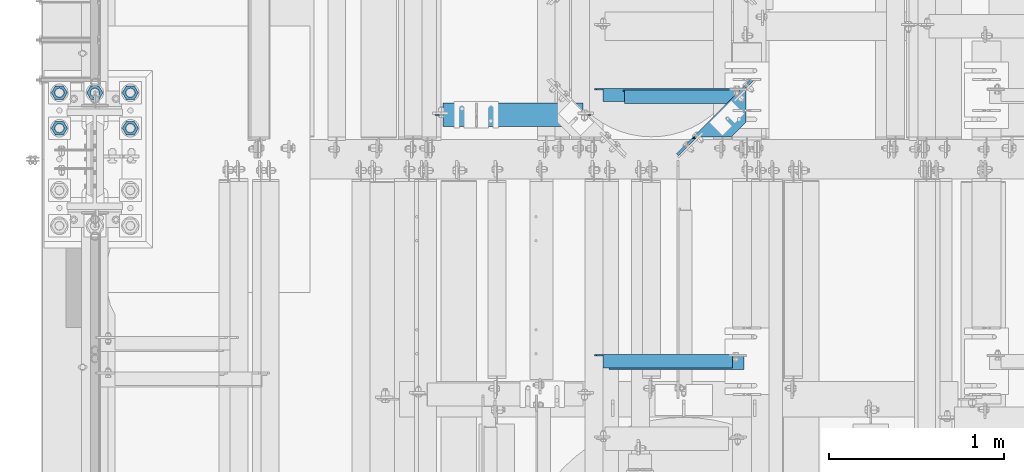
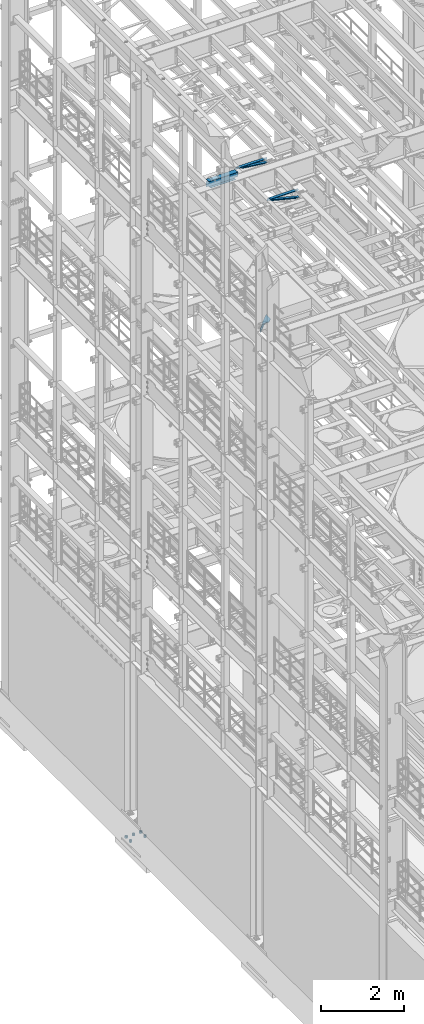
# One storey, part 1291 of 1876: 11 beams, 7 elements without a shape of their own.
"""IFC2X3 building model written with IfcOpenShell, lengths in millimetres."""

from ifc_helpers import new_model, si_unit, frame, origin_with_axes, place, context, subcontext, project, spatial, faceted_brep, material, type_object, element, aggregate, save


model = new_model("IFC2X3")

# Units and contexts
model_context = context("Model", 3, precision=1e-05, world=origin_with_axes())
body_context = subcontext(model_context, "Body", "Model", "MODEL_VIEW")
ifc_project = project(units=[si_unit("LENGTHUNIT", "METRE", prefix="MILLI"), si_unit("AREAUNIT", "SQUARE_METRE"), si_unit("VOLUMEUNIT", "CUBIC_METRE"), si_unit("MASSUNIT", "GRAM", prefix="KILO"), si_unit("TIMEUNIT", "SECOND"), si_unit("PLANEANGLEUNIT", "RADIAN"), si_unit("SOLIDANGLEUNIT", "STERADIAN"), si_unit("THERMODYNAMICTEMPERATUREUNIT", "DEGREE_CELSIUS"), si_unit("LUMINOUSINTENSITYUNIT", "LUMEN")], contexts=[model_context])

# Site, building, storey
site_placement = place(None, origin_with_axes())
site = spatial("IfcSite", under=ifc_project, at=site_placement, CompositionType="ELEMENT")
building_placement = place(site_placement, origin_with_axes())
building = spatial("IfcBuilding", under=site, at=building_placement, Name="Undefined", CompositionType="ELEMENT")
storey_placement = place(building_placement, origin_with_axes())
storey = spatial("IfcBuildingStorey", under=building, at=storey_placement, Name="Undefined", CompositionType="ELEMENT", Elevation=0.0)

# Assembly, beam
assembly_1_placement = place(storey_placement, origin_with_axes())
assembly_1 = element("IfcElementAssembly", 1, at=assembly_1_placement, inside=storey, AssemblyPlace="NOTDEFINED", PredefinedType="RIGID_FRAME")
ifc_material_1 = material(Name="STEEL/A36")
beam_type_1 = type_object("IfcBeamType", Name="L3X3X3/8", PredefinedType="NOTDEFINED")
beam_1_placement = place(assembly_1_placement, frame((2848.13301311816, 6454.18006051547, 17946.2692677152), z_axis=(0.0, -1.0, 0.0), x_axis=(0.969310558580603, 1.00000000454371e-07, -0.245839461893631)))
beam_1 = element("IfcBeam", 2, at=beam_1_placement, type_object=beam_type_1, material=ifc_material_1, ObjectType="L3X3X3/8", context=body_context, shape_type="Brep", body=[
    faceted_brep([(90.4045258935405, 38.0999999998276, -38.0999999999794), (90.4045258813046, 38.0999999997985, 38.1000000000213), (887.66431198654, 38.0999999985725, 38.1000000001395), (887.664311998776, 38.0999999986052, -38.0999999998612), (90.4045258813187, 28.5749999998079, 38.1000000000195), (887.664311986553, 28.5749999985892, 38.1000000001368), (90.4045258920253, 28.574999999837, -28.5749999999816), (887.664311997261, 28.5749999986147, -28.5749999998634), (90.4045258921208, -38.1000000000786, -28.5749999999953), (887.664311997356, -38.1000000012973, -28.5749999998779), (90.404525893651, -38.1000000000749, -38.0999999999967), (887.664311998886, -38.1000000012937, -38.0999999998776)], [[[0, 1, 2, 3]], [[1, 4, 5, 2]], [[4, 6, 7, 5]], [[6, 8, 9, 7]], [[8, 10, 11, 9]], [[10, 0, 3, 11]], [[5, 7, 9, 11, 3, 2]], [[10, 8, 6, 4, 1, 0]]]),
])
aggregate(assembly_1, [beam_1])

assembly_2_placement = place(storey_placement, origin_with_axes())
assembly_2 = element("IfcElementAssembly", 3, at=assembly_2_placement, inside=storey, Name="ANGLE", AssemblyPlace="NOTDEFINED", PredefinedType="RIGID_FRAME")
beam_2_placement = place(assembly_2_placement, frame((2857.49949562797, 6463.70506140095, 17945.1), z_axis=(0.0, -1.0, 0.0), x_axis=(1.0, 0.0, 0.0)))
beam_2 = element("IfcBeam", 4, at=beam_2_placement, type_object=beam_type_1, material=ifc_material_1, Name="ANGLE", ObjectType="L3X3X3/8", context=body_context, shape_type="Brep", body=[
    faceted_brep([(792.16350731529, 28.5750000000007, -28.5750000002181), (792.163500447734, 28.5750000000007, 38.0999999997821), (52.3875000813123, 28.5750001907327, 38.0999999999858), (52.3875051486311, 28.5750000000007, -28.5750000000144), (792.16312546001, 38.0999999999985, 38.099999999783), (52.3875000813496, 38.0999999999985, 38.0999999999858), (15.8755031573583, 28.5750000000007, -28.5750000000053), (15.875503881261, 28.5750001907327, -38.1000000000049), (3.17550407199587, 15.8750003814675, -38.1000000000013), (3.17550334809312, 15.8750003814675, -28.5750000000016), (52.3875058725339, 28.5750001907327, -38.1000000000149), (52.3875058725371, 38.0999999999985, -38.1000000000149), (792.16313330825, 38.0999999999985, -38.1000000002177), (792.163508296368, 28.5750017223145, -38.1000000002186), (860.425509047713, 28.5750000000007, -28.5750000002372), (860.425510028792, 28.5750017223145, -38.1000000002377), (873.125508856978, 15.8750030560368, -28.5750000002408), (873.125509838057, 15.8750019130493, -38.1000000002414), (873.125508856978, 3.17500420044598, -28.5750000002408), (873.125509838057, 3.17500305745853, -38.1000000002414), (873.125507331097, -38.0999999999985, -28.5750000002408), (873.125508312176, -38.0999999999985, -38.1000000002405), (3.17550731526535, -38.0999999999985, -28.5750000000007), (3.17550829634501, -38.0999999999985, -38.1000000000013), (3.17550407199587, 3.17500152587672, -38.1000000000013), (3.17550334809312, 3.17500152587672, -28.5750000000016)], [[[0, 1, 2, 3]], [[1, 4, 5, 2]], [[6, 7, 8, 9]], [[3, 10, 7, 6]], [[2, 5, 11, 10, 3]], [[4, 12, 11, 5]], [[1, 0, 13, 12, 4]], [[14, 15, 13, 0]], [[16, 17, 15, 14]], [[18, 19, 17, 16]], [[19, 18, 20, 21]], [[21, 20, 22, 23]], [[8, 7, 10, 11, 12, 13, 15, 17, 19, 21, 23, 24]], [[9, 8, 24, 25]], [[20, 18, 16, 14, 0, 3, 6, 9, 25, 22]], [[24, 23, 22, 25]]]),
])
aggregate(assembly_2, [beam_2])

assembly_3_placement = place(storey_placement, origin_with_axes())
assembly_3 = element("IfcElementAssembly", 5, at=assembly_3_placement, inside=storey, AssemblyPlace="NOTDEFINED", PredefinedType="RIGID_FRAME")
beam_3_placement = place(assembly_3_placement, frame((2852.70682935148, 7978.18213610312, 17945.4027002496), z_axis=(0.0, -1.0, 0.0), x_axis=(0.992055111518437, 1.02000000268371e-07, -0.125804036938932)))
beam_3 = element("IfcBeam", 6, at=beam_3_placement, type_object=beam_type_1, material=ifc_material_1, ObjectType="L3X3X3/8", context=body_context, shape_type="Brep", body=[
    faceted_brep([(176.663647192054, 38.0999999999221, -38.0999999999594), (176.663647205919, 38.0999999998421, 38.1000000000404), (867.316103043101, 38.0999999995292, 38.1000000001568), (867.316103029236, 38.0999999996056, -38.099999999843), (176.663647205922, 28.5749999998552, 38.1000000000377), (867.316103043104, 28.5749999995423, 38.100000000155), (176.663647193791, 28.5749999999207, -28.5749999999625), (867.316103030973, 28.5749999996078, -28.5749999998452), (176.663647193814, -38.1000000000131, -28.5749999999789), (867.316103030995, -38.1000000003223, -28.5749999998607), (176.663647192081, -38.1000000000022, -38.0999999999785), (867.316103029262, -38.1000000003114, -38.0999999998612)], [[[0, 1, 2, 3]], [[1, 4, 5, 2]], [[4, 6, 7, 5]], [[6, 8, 9, 7]], [[8, 10, 11, 9]], [[10, 0, 3, 11]], [[5, 7, 9, 11, 3, 2]], [[10, 8, 6, 4, 1, 0]]]),
])
aggregate(assembly_3, [beam_3])

assembly_4_placement = place(storey_placement, origin_with_axes())
assembly_4 = element("IfcElementAssembly", 7, at=assembly_4_placement, inside=storey, Name="ANGLE", AssemblyPlace="NOTDEFINED", PredefinedType="RIGID_FRAME")
beam_4_placement = place(assembly_4_placement, frame((2857.4999621662, 7987.7071365963, 17945.1), z_axis=(0.0, -1.0, 0.0), x_axis=(1.0, 0.0, 0.0)))
beam_4 = element("IfcBeam", 8, at=beam_4_placement, type_object=beam_type_1, material=ifc_material_1, Name="ANGLE", ObjectType="L3X3X3/8", context=body_context, shape_type="Brep", body=[
    faceted_brep([(792.163346802882, 28.5750000000007, -28.5750000002181), (792.163339935326, 28.5750000000007, 38.0999999997821), (52.3870335430847, 28.5750001907327, 38.0999999999858), (52.3869956588824, 28.5749999999955, -28.5750000000007), (792.162964935728, 38.0999999999985, 38.099999999783), (52.387033543122, 38.0999999999985, 38.0999999999858), (15.8750625152097, 28.5750000000007, -28.5749999999953), (15.8750613722059, 28.5750001907327, -38.0999999999958), (3.17506156294075, 15.8750003814675, -38.0999999999995), (3.17506270594458, 15.8750003814675, -28.5749999999989), (52.3870393343063, 28.5750001907327, -38.1000000000149), (52.3869953826566, 38.0999999999954, -38.0999999999985), (792.162972783968, 38.0999999999985, -38.1000000002177), (792.163347783961, 28.5750017223145, -38.1000000002186), (860.425348519473, 28.5750000000007, -28.5750000002372), (860.425349500552, 28.5750017223145, -38.1000000002368), (873.125348328738, 15.8750030560368, -28.5750000002408), (873.125349309817, 15.8750019130493, -38.1000000002405), (873.125348328738, 3.17500420044598, -28.5750000002408), (873.125349309817, 3.17500305745853, -38.1000000002405), (873.125346802857, -38.0999999999985, -28.5750000002408), (873.125347783936, -38.0999999999985, -38.1000000002405), (3.17506206535836, -38.0999999999985, -28.5749999999989), (3.17506108428279, -38.0999999999985, -38.0999999999995), (3.17506156294075, 3.17500152587672, -38.0999999999995), (3.17506270594458, 3.17500152587672, -28.5749999999989)], [[[0, 1, 2, 3]], [[1, 4, 5, 2]], [[6, 7, 8, 9]], [[3, 10, 7, 6]], [[2, 5, 11, 10, 3]], [[4, 12, 11, 5]], [[1, 0, 13, 12, 4]], [[14, 15, 13, 0]], [[16, 17, 15, 14]], [[18, 19, 17, 16]], [[19, 18, 20, 21]], [[21, 20, 22, 23]], [[8, 7, 10, 11, 12, 13, 15, 17, 19, 21, 23, 24]], [[9, 8, 24, 25]], [[20, 18, 16, 14, 0, 3, 6, 9, 25, 22]], [[24, 23, 22, 25]]]),
])
aggregate(assembly_4, [beam_4])

assembly_5_placement = place(storey_placement, origin_with_axes())
assembly_5 = element("IfcElementAssembly", 9, at=assembly_5_placement, inside=storey, Name="BEAM", AssemblyPlace="NOTDEFINED", PredefinedType="RIGID_FRAME")
ifc_material_2 = material(Name="STEEL/A992")
beam_type_2 = type_object("IfcBeamType", Name="W8X18", PredefinedType="NOTDEFINED")
beam_5_placement = place(assembly_5_placement, frame((1930.4, 7874.17044067383, 17880.0125), z_axis=(0.0, 0.0, 1.0), x_axis=(1.0, 0.0, 0.0)))
beam_5 = element("IfcBeam", 10, at=beam_5_placement, type_object=beam_type_2, material=ifc_material_2, Name="BEAM", ObjectType="W8X18", context=body_context, shape_type="Brep", body=[
    faceted_brep([(15.875, -3.17500000000018, -77.7874999999949), (15.875, 3.17500000000018, -77.7874999999949), (95.2500001907356, 3.17500000000018, -77.7874999999949), (95.2500001907356, -3.17500000000018, -77.7874999999949), (100.110079708781, 3.17500000000018, -78.7542299225825), (100.110079708781, -3.17500000000018, -78.7542299225825), (104.230256176935, 3.17500000000018, -81.50724382306), (104.230256176935, -3.17500000000018, -81.50724382306), (106.983270077413, 3.17500000000018, -85.6274202912136), (106.983270077413, -3.17500000000018, -85.6274202912136), (107.950000000001, -3.17500000000018, -90.48749980926), (107.950000000001, 3.17500000000018, -90.48749980926), (107.950000000001, 3.17500000000018, -95.25), (107.950000000001, 66.6750000000002, -95.25), (107.950000000001, 66.6750000000002, -103.1875), (107.950000000001, -66.6750000000002, -103.1875), (107.950000000001, -66.6750000000002, -95.25), (107.950000000001, -3.17500000000018, -95.25), (63.1842266547242, -66.6750000000002, 95.25), (863.915773345279, -66.6750000000002, 95.25), (863.600000000002, -66.6750000000002, 96.8374998092695), (863.600000000002, -66.6750000000002, 103.1875), (63.5000000000009, -66.6750000000002, 103.1875), (63.5000000000009, -66.6750000000002, 96.8374998092695), (863.600000000002, 66.6750000000002, 96.8374998092695), (863.600000000002, 66.6750000000002, 103.1875), (63.5000000000009, 66.6750000000002, 103.1875), (63.5000000000009, 66.6750000000002, 96.8374998092695), (863.915773345279, 66.6750000000002, 95.25), (63.1842266547242, 66.6750000000002, 95.25), (863.915773345279, 3.17500000000018, 95.25), (63.1842266547242, 3.17500000000018, 95.25), (50.8000001907358, -3.17500000000018, 84.1375000000044), (50.8000001907358, 3.17500000000018, 84.1375000000044), (15.875, 3.17500000000018, 84.1375000000044), (15.875, -3.17500000000018, 84.1375000000044), (55.6600797087813, -3.17500000000018, 85.1042299225919), (55.6600797087813, 3.17500000000018, 85.1042299225919), (59.7802561769349, -3.17500000000018, 87.8572438230694), (59.7802561769349, 3.17500000000018, 87.8572438230694), (62.5332700774129, -3.17500000000018, 91.9774202912231), (62.5332700774129, 3.17500000000018, 91.9774202912231), (63.1842266547242, -3.17500000000018, 95.25), (863.915773345279, -3.17500000000018, 95.25), (864.56672992259, -3.17500000000018, 91.9774202912231), (864.56672992259, 3.17500000000018, 91.9774202912231), (867.319743823068, -3.17500000000018, 87.8572438230694), (867.319743823068, 3.17500000000018, 87.8572438230694), (871.439920291222, -3.17500000000018, 85.1042299225919), (871.439920291222, 3.17500000000018, 85.1042299225919), (876.299999809267, -3.17500000000018, 84.1375000000044), (876.299999809267, 3.17500000000018, 84.1375000000044), (911.225000000001, -3.17500000000018, 84.1375000000044), (911.225000000001, 3.17500000000018, 84.1375000000044), (911.225000000001, -3.17500000000018, -77.7874999999949), (911.225000000001, 3.17500000000018, -77.7874999999949), (831.849999809268, -3.17500000000018, -77.7874999999949), (831.849999809268, 3.17500000000018, -77.7874999999949), (826.989920291222, -3.17500000000018, -78.7542299225825), (826.989920291222, 3.17500000000018, -78.7542299225825), (822.869743823068, -3.17500000000018, -81.50724382306), (822.869743823068, 3.17500000000018, -81.50724382306), (820.11672992259, -3.17500000000018, -85.6274202912136), (820.11672992259, 3.17500000000018, -85.6274202912136), (819.150000000002, -3.17500000000018, -90.48749980926), (819.150000000002, 3.17500000000018, -90.48749980926), (819.150000000002, -3.17500000000018, -95.25), (819.150000000002, -66.6750000000002, -95.25), (819.150000000002, -66.6750000000002, -103.1875), (819.150000000002, 66.6750000000002, -103.1875), (819.150000000002, 66.6750000000002, -95.25), (819.150000000002, 3.17500000000018, -95.25)], [[[0, 1, 2, 3]], [[3, 2, 4, 5]], [[5, 4, 6, 7]], [[7, 6, 8, 9]], [[10, 11, 12, 13, 14, 15, 16, 17]], [[9, 8, 11, 10]], [[18, 19, 20, 21, 22, 23]], [[21, 20, 24, 25]], [[21, 25, 26, 22]], [[22, 26, 27, 23]], [[25, 24, 28, 29, 27, 26]], [[28, 30, 31, 29]], [[32, 33, 34, 35]], [[36, 37, 33, 32]], [[38, 39, 37, 36]], [[40, 41, 39, 38]], [[23, 27, 29, 31, 41, 40, 42, 18]], [[43, 19, 18, 42]], [[44, 45, 30, 28, 24, 20, 19, 43]], [[46, 47, 45, 44]], [[48, 49, 47, 46]], [[50, 51, 49, 48]], [[52, 53, 51, 50]], [[53, 52, 54, 55]], [[54, 56, 57, 55]], [[58, 59, 57, 56]], [[60, 61, 59, 58]], [[62, 63, 61, 60]], [[64, 65, 63, 62]], [[66, 67, 68, 69, 70, 71, 65, 64]], [[67, 66, 17, 16]], [[68, 67, 16, 15]], [[69, 68, 15, 14]], [[70, 69, 14, 13]], [[71, 70, 13, 12]], [[6, 4, 2, 1, 34, 33, 37, 39, 41, 31, 30, 45, 47, 49, 51, 53, 55, 57, 59, 61, 63, 65, 71, 12, 11, 8]], [[35, 34, 1, 0]], [[66, 64, 62, 60, 58, 56, 54, 52, 50, 48, 46, 44, 43, 42, 40, 38, 36, 32, 35, 0, 3, 5, 7, 9, 10, 17]]]),
])
aggregate(assembly_5, [beam_5])

# Assembly, beams
assembly_6_placement = place(storey_placement, origin_with_axes())
assembly_6 = element("IfcElementAssembly", 11, at=assembly_6_placement, inside=storey, Name="TEMPLATE", AssemblyPlace="NOTDEFINED", PredefinedType="RIGID_FRAME")
ifc_material_3 = material(Name="STEEL/A563")
beam_type_3 = type_object("IfcBeamType", Name="2_HEAVY_HEX_NUT", PredefinedType="NOTDEFINED")
beam_6_placement = place(assembly_6_placement, frame((-203.2, 7797.79999847412, -685.799998474121), z_axis=(0.0, -1.0, 0.0), x_axis=(0.0, 0.0, -1.0)))
beam_6 = element("IfcBeam", 12, at=beam_6_placement, type_object=beam_type_3, material=ifc_material_3, Name="NUT", ObjectType="2_HEAVY_HEX_NUT", context=body_context, shape_type="Brep", body=[
    faceted_brep([(0.0, -46.0369987487793, 9.09494701772928e-13), (0.0, -23.0184993743896, -39.869213104248), (50.8, -23.0184993743896, -39.869213104248), (50.8, -46.0369987487793, 9.09494701772928e-13), (0.0, 23.0184993743896, -39.869213104248), (50.8, 23.0184993743896, -39.869213104248), (0.0, 46.0369987487793, -9.09494701772928e-13), (50.8, 46.0369987487793, -9.09494701772928e-13), (0.0, 23.0184993743896, 39.869213104248), (50.8, 23.0184993743896, 39.869213104248), (0.0, -23.0184993743896, 39.869213104248), (50.8, -23.0184993743896, 39.869213104248), (0.0, 0.0, 26.1940002441406), (0.0, 11.3650617044514, 23.5999013092769), (50.8, 11.3650617044513, 23.5999013092771), (50.8, 0.0, 26.1940002441406), (0.0, 20.4791109456437, 16.3316083006703), (50.8, 20.4791109456439, 16.3316083006703), (0.0, 25.5370200498346, 5.82867859874477), (50.8, 25.5370200498343, 5.82867859874455), (0.0, 25.5370200498346, -5.82867859874477), (50.8, 25.5370200498343, -5.82867859874455), (0.0, 20.4791109456437, -16.3316083006703), (50.8, 20.4791109456439, -16.3316083006703), (0.0, 11.3650617044514, -23.5999013092769), (50.8, 11.3650617044514, -23.5999013092771), (0.0, 0.0, -26.1940002441406), (50.8, 0.0, -26.1940002441406), (0.0, -11.3650617044514, -23.5999013092769), (50.8, -11.3650617044513, -23.5999013092771), (0.0, -20.4791109456437, -16.3316083006703), (50.8, -20.4791109456439, -16.3316083006703), (0.0, -25.5370200498346, -5.82867859874477), (50.8, -25.5370200498343, -5.82867859874455), (0.0, -25.5370200498346, 5.82867859874477), (50.8, -25.5370200498343, 5.82867859874455), (0.0, -20.4791109456437, 16.3316083006703), (50.8, -20.4791109456439, 16.3316083006703), (0.0, -11.3650617044514, 23.5999013092769), (50.8, -11.3650617044514, 23.5999013092771)], [[[0, 1, 2, 3]], [[1, 4, 5, 2]], [[4, 6, 7, 5]], [[6, 8, 9, 7]], [[8, 10, 11, 9]], [[10, 0, 3, 11]], [[12, 13, 14, 15]], [[13, 16, 17, 14]], [[16, 18, 19, 17]], [[18, 20, 21, 19]], [[20, 22, 23, 21]], [[22, 24, 25, 23]], [[24, 26, 27, 25]], [[26, 28, 29, 27]], [[28, 30, 31, 29]], [[30, 32, 33, 31]], [[32, 34, 35, 33]], [[34, 36, 37, 35]], [[36, 38, 39, 37]], [[38, 12, 15, 39]], [[5, 7, 9, 11, 3, 2], [17, 19, 21, 23, 25, 27, 29, 31, 33, 35, 37, 39, 15, 14]], [[10, 8, 6, 4, 1, 0], [38, 36, 34, 32, 30, 28, 26, 24, 22, 20, 18, 16, 13, 12]]]),
])
beam_7_placement = place(assembly_6_placement, frame((203.2, 7797.79999847412, -685.799998474121), z_axis=(0.0, 1.0, 0.0), x_axis=(0.0, 0.0, -1.0)))
beam_7 = element("IfcBeam", 13, at=beam_7_placement, type_object=beam_type_3, material=ifc_material_3, Name="NUT", ObjectType="2_HEAVY_HEX_NUT", context=body_context, shape_type="Brep", body=[
    faceted_brep([(0.0, -46.0369987487793, 9.09494701772928e-13), (0.0, -23.0184993743896, -39.869213104248), (50.8, -23.0184993743896, -39.869213104248), (50.8, -46.0369987487793, 9.09494701772928e-13), (0.0, 23.0184993743896, -39.869213104248), (50.8, 23.0184993743896, -39.869213104248), (0.0, 46.0369987487793, -9.09494701772928e-13), (50.8, 46.0369987487793, -9.09494701772928e-13), (0.0, 23.0184993743896, 39.869213104248), (50.8, 23.0184993743896, 39.869213104248), (0.0, -23.0184993743896, 39.869213104248), (50.8, -23.0184993743896, 39.869213104248), (0.0, 0.0, 26.1940002441406), (0.0, 11.3650617044514, 23.5999013092769), (50.8, 11.3650617044513, 23.5999013092771), (50.8, 0.0, 26.1940002441406), (0.0, 20.4791109456437, 16.3316083006703), (50.8, 20.4791109456439, 16.3316083006703), (0.0, 25.5370200498346, 5.82867859874477), (50.8, 25.5370200498343, 5.82867859874455), (0.0, 25.5370200498346, -5.82867859874477), (50.8, 25.5370200498343, -5.82867859874455), (0.0, 20.4791109456437, -16.3316083006703), (50.8, 20.4791109456439, -16.3316083006703), (0.0, 11.3650617044514, -23.5999013092769), (50.8, 11.3650617044514, -23.5999013092771), (0.0, 0.0, -26.1940002441406), (50.8, 0.0, -26.1940002441406), (0.0, -11.3650617044514, -23.5999013092769), (50.8, -11.3650617044513, -23.5999013092771), (0.0, -20.4791109456437, -16.3316083006703), (50.8, -20.4791109456439, -16.3316083006703), (0.0, -25.5370200498346, -5.82867859874477), (50.8, -25.5370200498343, -5.82867859874455), (0.0, -25.5370200498346, 5.82867859874477), (50.8, -25.5370200498343, 5.82867859874455), (0.0, -20.4791109456437, 16.3316083006703), (50.8, -20.4791109456439, 16.3316083006703), (0.0, -11.3650617044514, 23.5999013092769), (50.8, -11.3650617044514, 23.5999013092771)], [[[0, 1, 2, 3]], [[1, 4, 5, 2]], [[4, 6, 7, 5]], [[6, 8, 9, 7]], [[8, 10, 11, 9]], [[10, 0, 3, 11]], [[12, 13, 14, 15]], [[13, 16, 17, 14]], [[16, 18, 19, 17]], [[18, 20, 21, 19]], [[20, 22, 23, 21]], [[22, 24, 25, 23]], [[24, 26, 27, 25]], [[26, 28, 29, 27]], [[28, 30, 31, 29]], [[30, 32, 33, 31]], [[32, 34, 35, 33]], [[34, 36, 37, 35]], [[36, 38, 39, 37]], [[38, 12, 15, 39]], [[5, 7, 9, 11, 3, 2], [17, 19, 21, 23, 25, 27, 29, 31, 33, 35, 37, 39, 15, 14]], [[10, 8, 6, 4, 1, 0], [38, 36, 34, 32, 30, 28, 26, 24, 22, 20, 18, 16, 13, 12]]]),
])
beam_8_placement = place(assembly_6_placement, frame((-203.2, 8000.99999847412, -685.799998474121), z_axis=(0.0, -1.0, 0.0), x_axis=(0.0, 0.0, -1.0)))
beam_8 = element("IfcBeam", 14, at=beam_8_placement, type_object=beam_type_3, material=ifc_material_3, Name="NUT", ObjectType="2_HEAVY_HEX_NUT", context=body_context, shape_type="Brep", body=[
    faceted_brep([(0.0, -46.0369987487793, 9.09494701772928e-13), (0.0, -23.0184993743896, -39.869213104248), (50.8, -23.0184993743896, -39.869213104248), (50.8, -46.0369987487793, 9.09494701772928e-13), (0.0, 23.0184993743896, -39.869213104248), (50.8, 23.0184993743896, -39.869213104248), (0.0, 46.0369987487793, -9.09494701772928e-13), (50.8, 46.0369987487793, -9.09494701772928e-13), (0.0, 23.0184993743896, 39.869213104248), (50.8, 23.0184993743896, 39.869213104248), (0.0, -23.0184993743896, 39.869213104248), (50.8, -23.0184993743896, 39.869213104248), (0.0, 0.0, 26.1940002441406), (0.0, 11.3650617044514, 23.5999013092769), (50.8, 11.3650617044513, 23.5999013092771), (50.8, 0.0, 26.1940002441406), (0.0, 20.4791109456437, 16.3316083006703), (50.8, 20.4791109456439, 16.3316083006703), (0.0, 25.5370200498346, 5.82867859874477), (50.8, 25.5370200498343, 5.82867859874455), (0.0, 25.5370200498346, -5.82867859874477), (50.8, 25.5370200498343, -5.82867859874455), (0.0, 20.4791109456437, -16.3316083006703), (50.8, 20.4791109456439, -16.3316083006703), (0.0, 11.3650617044514, -23.5999013092769), (50.8, 11.3650617044514, -23.5999013092771), (0.0, 0.0, -26.1940002441406), (50.8, 0.0, -26.1940002441406), (0.0, -11.3650617044514, -23.5999013092769), (50.8, -11.3650617044513, -23.5999013092771), (0.0, -20.4791109456437, -16.3316083006703), (50.8, -20.4791109456439, -16.3316083006703), (0.0, -25.5370200498346, -5.82867859874477), (50.8, -25.5370200498343, -5.82867859874455), (0.0, -25.5370200498346, 5.82867859874477), (50.8, -25.5370200498343, 5.82867859874455), (0.0, -20.4791109456437, 16.3316083006703), (50.8, -20.4791109456439, 16.3316083006703), (0.0, -11.3650617044514, 23.5999013092769), (50.8, -11.3650617044514, 23.5999013092771)], [[[0, 1, 2, 3]], [[1, 4, 5, 2]], [[4, 6, 7, 5]], [[6, 8, 9, 7]], [[8, 10, 11, 9]], [[10, 0, 3, 11]], [[12, 13, 14, 15]], [[13, 16, 17, 14]], [[16, 18, 19, 17]], [[18, 20, 21, 19]], [[20, 22, 23, 21]], [[22, 24, 25, 23]], [[24, 26, 27, 25]], [[26, 28, 29, 27]], [[28, 30, 31, 29]], [[30, 32, 33, 31]], [[32, 34, 35, 33]], [[34, 36, 37, 35]], [[36, 38, 39, 37]], [[38, 12, 15, 39]], [[5, 7, 9, 11, 3, 2], [17, 19, 21, 23, 25, 27, 29, 31, 33, 35, 37, 39, 15, 14]], [[10, 8, 6, 4, 1, 0], [38, 36, 34, 32, 30, 28, 26, 24, 22, 20, 18, 16, 13, 12]]]),
])
beam_9_placement = place(assembly_6_placement, frame((0.0, 8000.99999847412, -685.799998474121), z_axis=(0.0, -1.0, 0.0), x_axis=(0.0, 0.0, -1.0)))
beam_9 = element("IfcBeam", 15, at=beam_9_placement, type_object=beam_type_3, material=ifc_material_3, Name="NUT", ObjectType="2_HEAVY_HEX_NUT", context=body_context, shape_type="Brep", body=[
    faceted_brep([(0.0, -46.0369987487793, 9.09494701772928e-13), (0.0, -23.0184993743896, -39.869213104248), (50.8, -23.0184993743896, -39.869213104248), (50.8, -46.0369987487793, 9.09494701772928e-13), (0.0, 23.0184993743896, -39.869213104248), (50.8, 23.0184993743896, -39.869213104248), (0.0, 46.0369987487793, -9.09494701772928e-13), (50.8, 46.0369987487793, -9.09494701772928e-13), (0.0, 23.0184993743896, 39.869213104248), (50.8, 23.0184993743896, 39.869213104248), (0.0, -23.0184993743896, 39.869213104248), (50.8, -23.0184993743896, 39.869213104248), (0.0, 0.0, 26.1940002441406), (0.0, 11.3650617044514, 23.5999013092769), (50.8, 11.3650617044513, 23.5999013092771), (50.8, 0.0, 26.1940002441406), (0.0, 20.4791109456437, 16.3316083006703), (50.8, 20.4791109456439, 16.3316083006703), (0.0, 25.5370200498346, 5.82867859874477), (50.8, 25.5370200498343, 5.82867859874455), (0.0, 25.5370200498346, -5.82867859874477), (50.8, 25.5370200498343, -5.82867859874455), (0.0, 20.4791109456437, -16.3316083006703), (50.8, 20.4791109456439, -16.3316083006703), (0.0, 11.3650617044514, -23.5999013092769), (50.8, 11.3650617044514, -23.5999013092771), (0.0, 0.0, -26.1940002441406), (50.8, 0.0, -26.1940002441406), (0.0, -11.3650617044514, -23.5999013092769), (50.8, -11.3650617044513, -23.5999013092771), (0.0, -20.4791109456437, -16.3316083006703), (50.8, -20.4791109456439, -16.3316083006703), (0.0, -25.5370200498346, -5.82867859874477), (50.8, -25.5370200498343, -5.82867859874455), (0.0, -25.5370200498346, 5.82867859874477), (50.8, -25.5370200498343, 5.82867859874455), (0.0, -20.4791109456437, 16.3316083006703), (50.8, -20.4791109456439, 16.3316083006703), (0.0, -11.3650617044514, 23.5999013092769), (50.8, -11.3650617044514, 23.5999013092771)], [[[0, 1, 2, 3]], [[1, 4, 5, 2]], [[4, 6, 7, 5]], [[6, 8, 9, 7]], [[8, 10, 11, 9]], [[10, 0, 3, 11]], [[12, 13, 14, 15]], [[13, 16, 17, 14]], [[16, 18, 19, 17]], [[18, 20, 21, 19]], [[20, 22, 23, 21]], [[22, 24, 25, 23]], [[24, 26, 27, 25]], [[26, 28, 29, 27]], [[28, 30, 31, 29]], [[30, 32, 33, 31]], [[32, 34, 35, 33]], [[34, 36, 37, 35]], [[36, 38, 39, 37]], [[38, 12, 15, 39]], [[5, 7, 9, 11, 3, 2], [17, 19, 21, 23, 25, 27, 29, 31, 33, 35, 37, 39, 15, 14]], [[10, 8, 6, 4, 1, 0], [38, 36, 34, 32, 30, 28, 26, 24, 22, 20, 18, 16, 13, 12]]]),
])
beam_10_placement = place(assembly_6_placement, frame((203.2, 8000.99999847412, -685.799998474121), z_axis=(0.0, 1.0, 0.0), x_axis=(0.0, 0.0, -1.0)))
beam_10 = element("IfcBeam", 16, at=beam_10_placement, type_object=beam_type_3, material=ifc_material_3, Name="NUT", ObjectType="2_HEAVY_HEX_NUT", context=body_context, shape_type="Brep", body=[
    faceted_brep([(0.0, -46.0369987487793, 9.09494701772928e-13), (0.0, -23.0184993743896, -39.869213104248), (50.8, -23.0184993743896, -39.869213104248), (50.8, -46.0369987487793, 9.09494701772928e-13), (0.0, 23.0184993743896, -39.869213104248), (50.8, 23.0184993743896, -39.869213104248), (0.0, 46.0369987487793, -9.09494701772928e-13), (50.8, 46.0369987487793, -9.09494701772928e-13), (0.0, 23.0184993743896, 39.869213104248), (50.8, 23.0184993743896, 39.869213104248), (0.0, -23.0184993743896, 39.869213104248), (50.8, -23.0184993743896, 39.869213104248), (0.0, 0.0, 26.1940002441406), (0.0, 11.3650617044514, 23.5999013092769), (50.8, 11.3650617044513, 23.5999013092771), (50.8, 0.0, 26.1940002441406), (0.0, 20.4791109456437, 16.3316083006703), (50.8, 20.4791109456439, 16.3316083006703), (0.0, 25.5370200498346, 5.82867859874477), (50.8, 25.5370200498343, 5.82867859874455), (0.0, 25.5370200498346, -5.82867859874477), (50.8, 25.5370200498343, -5.82867859874455), (0.0, 20.4791109456437, -16.3316083006703), (50.8, 20.4791109456439, -16.3316083006703), (0.0, 11.3650617044514, -23.5999013092769), (50.8, 11.3650617044514, -23.5999013092771), (0.0, 0.0, -26.1940002441406), (50.8, 0.0, -26.1940002441406), (0.0, -11.3650617044514, -23.5999013092769), (50.8, -11.3650617044513, -23.5999013092771), (0.0, -20.4791109456437, -16.3316083006703), (50.8, -20.4791109456439, -16.3316083006703), (0.0, -25.5370200498346, -5.82867859874477), (50.8, -25.5370200498343, -5.82867859874455), (0.0, -25.5370200498346, 5.82867859874477), (50.8, -25.5370200498343, 5.82867859874455), (0.0, -20.4791109456437, 16.3316083006703), (50.8, -20.4791109456439, 16.3316083006703), (0.0, -11.3650617044514, 23.5999013092769), (50.8, -11.3650617044514, 23.5999013092771)], [[[0, 1, 2, 3]], [[1, 4, 5, 2]], [[4, 6, 7, 5]], [[6, 8, 9, 7]], [[8, 10, 11, 9]], [[10, 0, 3, 11]], [[12, 13, 14, 15]], [[13, 16, 17, 14]], [[16, 18, 19, 17]], [[18, 20, 21, 19]], [[20, 22, 23, 21]], [[22, 24, 25, 23]], [[24, 26, 27, 25]], [[26, 28, 29, 27]], [[28, 30, 31, 29]], [[30, 32, 33, 31]], [[32, 34, 35, 33]], [[34, 36, 37, 35]], [[36, 38, 39, 37]], [[38, 12, 15, 39]], [[5, 7, 9, 11, 3, 2], [17, 19, 21, 23, 25, 27, 29, 31, 33, 35, 37, 39, 15, 14]], [[10, 8, 6, 4, 1, 0], [38, 36, 34, 32, 30, 28, 26, 24, 22, 20, 18, 16, 13, 12]]]),
])
aggregate(assembly_6, [beam_6, beam_7, beam_8, beam_9, beam_10])

# Assembly, beam
assembly_7_placement = place(storey_placement, origin_with_axes())
assembly_7 = element("IfcElementAssembly", 17, at=assembly_7_placement, inside=storey, Name="BEAM", AssemblyPlace="NOTDEFINED", PredefinedType="RIGID_FRAME")
beam_type_4 = type_object("IfcBeamType", Name="L6X6X5/8", PredefinedType="NOTDEFINED")
beam_11_placement = place(assembly_7_placement, frame((3353.88948776159, 7566.11846327174, 13233.4), z_axis=(0.707106781186547, -0.707106781186548, 0.0), x_axis=(0.707106781186548, 0.707106781186547, 0.0)))
beam_11 = element("IfcBeam", 18, at=beam_11_placement, type_object=beam_type_4, material=ifc_material_1, Name="BEAM", ObjectType="L6X6X5/8", context=body_context, shape_type="Brep", body=[
    faceted_brep([(604.494342775935, 76.2000000000007, -76.2000000000112), (604.494342775935, 57.1499998092659, -76.2000000000116), (605.861505343611, 52.2899202912195, -76.2000000000116), (609.754854939072, 48.1697438230658, -76.2000000000126), (615.581664379706, 45.4167299225883, -76.2000000000116), (622.454854748341, 44.4500000000007, -76.2000000000121), (655.971263682824, 44.4500000000007, -76.2000000000112), (655.971263682824, -76.2000000000007, -76.2000000000112), (43.9383003809671, -76.2000000000007, -76.2000000000116), (43.9383003809671, 38.1000000000004, -76.2000000000116), (161.644610451713, 38.1000000000004, -76.2000000000116), (168.517800820347, 39.0667299225879, -76.2000000000121), (174.344610260981, 41.8197438230654, -76.2000000000126), (178.237959856441, 45.9399202912191, -76.2000000000112), (179.605122424117, 50.7999998092655, -76.2000000000126), (179.605122424117, 76.2000000000007, -76.2000000000126), (452.09434277591, 76.2000000000007, 76.2000000000139), (332.005122424143, 76.2000000000007, 76.2000000000135), (588.619342775934, 60.3250000000007, -60.3250000000085), (452.09434277591, 60.3250000000007, 76.2000000000139), (332.005122424143, 60.3250000000007, 76.2000000000135), (195.48012242412, 60.3250000000007, -60.3250000000098), (588.619342775934, 57.1499998092659, -60.3250000000089), (589.98650534361, 52.2899202912195, -60.3250000000089), (593.879854939069, 48.1697438230658, -60.3250000000089), (599.706664379704, 45.4167299225883, -60.3250000000089), (606.579854748337, 44.4500000000007, -60.3250000000094), (655.971263682832, 44.4500000000007, -60.3250000000089), (655.971263682832, -76.2000000000007, -60.3250000000089), (43.9383003809671, -76.2000000000007, -60.3250000000098), (43.9383003809671, 38.1000000000004, -60.3250000000098), (177.519610451716, 38.1000000000004, -60.3250000000089), (184.392800820349, 39.0667299225879, -60.3250000000098), (190.219610260985, 41.8197438230654, -60.3250000000094), (194.112959856444, 45.9399202912191, -60.3250000000085), (195.48012242412, 50.7999998092655, -60.3250000000098)], [[[0, 1, 2, 3, 4, 5, 6, 7, 8, 9, 10, 11, 12, 13, 14, 15]], [[16, 0, 15, 17]], [[18, 19, 20, 21]], [[0, 16, 19, 18, 22, 1]], [[1, 22, 23, 2]], [[2, 23, 24, 3]], [[3, 24, 25, 4]], [[4, 25, 26, 5]], [[27, 6, 5, 26]], [[28, 7, 6, 27]], [[7, 28, 29, 8]], [[8, 29, 30, 9]], [[31, 10, 9, 30]], [[32, 11, 10, 31]], [[33, 12, 11, 32]], [[34, 13, 12, 33]], [[35, 14, 13, 34]], [[33, 32, 31, 30, 29, 28, 27, 26, 25, 24, 23, 22, 18, 21, 35, 34]], [[20, 17, 15, 14, 35, 21]], [[19, 16, 17, 20]]]),
])
aggregate(assembly_7, [beam_11])

save(model, "model.ifc")
